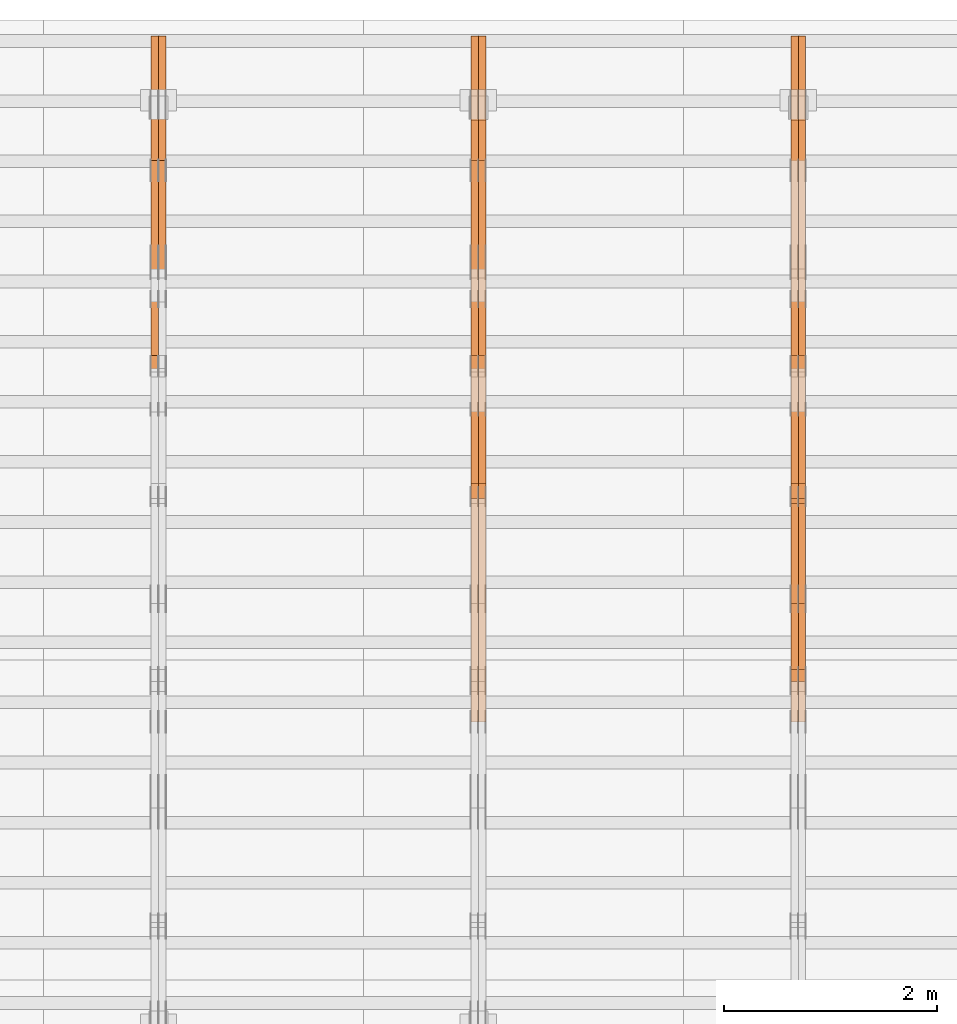
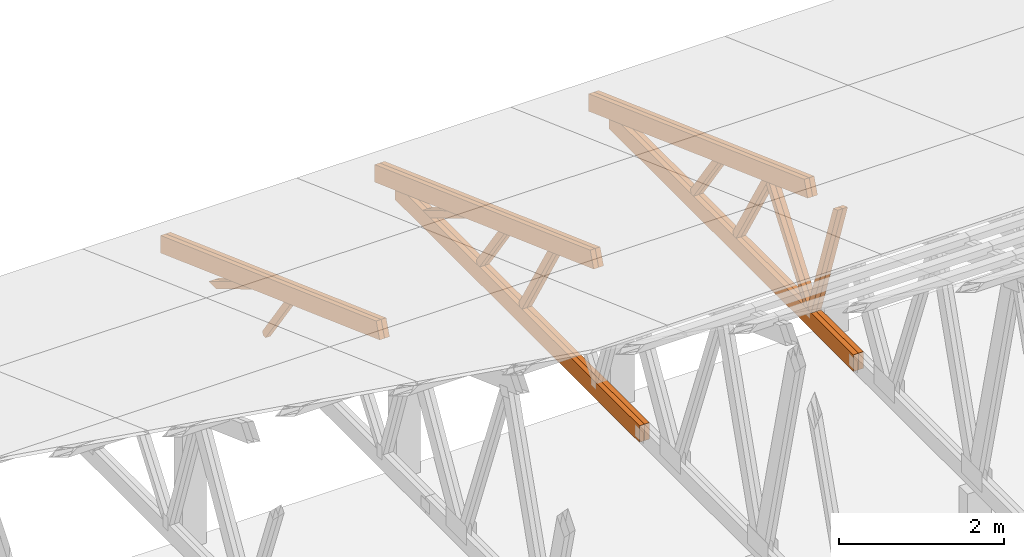
# One storey, part 43 of 189: 27 proxies.
"""IFC2X3 building model written with IfcOpenShell, lengths in millimetres."""

import ifcopenshell
import ifcopenshell.guid

model = None  # the IFC model being written
_history = None  # IfcOwnerHistory: only IFC2X3 demands one
_inside = {}  # id of a spatial element -> (the spatial element, [elements in it])
_under = {}  # id of a project, library or spatial element -> (it, [spatial elements below it])
_declared = {}  # id of a project -> (the project, [libraries it declares])
_typed = {}  # id of a type object -> (the type object, [elements of that type])
_made_of = {}  # id of a material, layer set ... -> (it, [elements and type objects made of it])


def new_model(schema):
    """Start an empty IFC model of exactly this schema.

    Asked for "IFC4X3", IfcOpenShell would pick the latest addendum, in which some entities
    have other attributes; the version numbers below select the first issue.
    IFC2X3 requires an IfcOwnerHistory on every rooted entity: one is made here for all.
    """
    global model, _history
    if schema == "IFC4X3":
        model = ifcopenshell.file(schema_version=(4, 3, 0, 0))
    else:
        model = ifcopenshell.file(schema=schema)
    _inside.clear()
    _under.clear()
    _declared.clear()
    _typed.clear()
    _made_of.clear()
    _history = None
    if model.schema == "IFC2X3":
        org = make("IfcOrganization", Name="unknown")
        user = make(
            "IfcPersonAndOrganization",
            ThePerson=make("IfcPerson", FamilyName="unknown"),
            TheOrganization=org,
        )
        app = make(
            "IfcApplication",
            ApplicationDeveloper=org,
            Version="unknown",
            ApplicationFullName="unknown",
            ApplicationIdentifier="unknown",
        )
        _history = make(
            "IfcOwnerHistory",
            OwningUser=user,
            OwningApplication=app,
            ChangeAction="ADDED",
            CreationDate=0,
        )
    return model


def make(cls, **values):
    """One entity of the class cls with the attributes given. An attribute that is None is left unset."""
    return model.create_entity(
        cls, **{name: value for name, value in values.items() if value is not None}
    )


def entity(cls, *values):
    """Any entity or typed value of the class cls, its attributes in the order of the schema. None: left unset."""
    e = model.create_entity(cls)
    for i, value in enumerate(values):
        if value is not None:
            e[i] = value
    return e


def rooted(cls, **values):
    """An entity with a GlobalId (a new one), such as an element, a storey or a relation."""
    return make(cls, GlobalId=ifcopenshell.guid.new(), OwnerHistory=_history, **values)


def si_unit(unit_type, name, prefix=None):
    """IfcSIUnit, for example si_unit("LENGTHUNIT", "METRE", prefix="MILLI")."""
    return make("IfcSIUnit", UnitType=unit_type, Prefix=prefix, Name=name)


def converted_unit(unit_type, name, factor, base, dimensions=None, offset=None):
    """IfcConversionBasedUnit, such as the inch: factor (a typed value) times the base unit."""
    return make(
        "IfcConversionBasedUnit"
        if offset is None
        else "IfcConversionBasedUnitWithOffset",
        ConversionOffset=offset,
        Dimensions=None
        if dimensions is None
        else entity("IfcDimensionalExponents", *dimensions),
        UnitType=unit_type,
        Name=name,
        ConversionFactor=make(
            "IfcMeasureWithUnit", ValueComponent=factor, UnitComponent=base
        ),
    )


def derived_unit(unit_type, elements):
    """IfcDerivedUnit: a product of units, each with its exponent."""
    return make(
        "IfcDerivedUnit",
        Elements=[
            make("IfcDerivedUnitElement", Unit=unit, Exponent=power)
            for unit, power in elements
        ],
        UnitType=unit_type,
    )


def assignment(units):
    """IfcUnitAssignment: the units of a project."""
    return None if units is None else make("IfcUnitAssignment", Units=units)


def point(xyz):
    """IfcCartesianPoint."""
    return None if xyz is None else make("IfcCartesianPoint", Coordinates=xyz)


def direction(xyz):
    """IfcDirection."""
    return None if xyz is None else make("IfcDirection", DirectionRatios=xyz)


def frame(location, z_axis=None, x_axis=None):
    """IfcAxis2Placement3D, a coordinate frame: its origin and axes. An axis left out is left unset."""
    return make(
        "IfcAxis2Placement3D",
        Location=point(location),
        Axis=direction(z_axis),
        RefDirection=direction(x_axis),
    )


def origin():
    """The frame at (0, 0, 0) with its axes left unset."""
    return frame((0.0, 0.0, 0.0))


def place(relative_to, where):
    """IfcLocalPlacement: puts the frame where relative to a parent placement (None: the world)."""
    return make(
        "IfcLocalPlacement", PlacementRelTo=relative_to, RelativePlacement=where
    )


def context(
    kind, dimensions, precision=None, world=None, true_north=None, identifier=None
):
    """IfcGeometricRepresentationContext, for example the 3D "Model" context."""
    return make(
        "IfcGeometricRepresentationContext",
        ContextIdentifier=identifier,
        ContextType=kind,
        CoordinateSpaceDimension=dimensions,
        Precision=precision,
        WorldCoordinateSystem=world,
        TrueNorth=true_north,
    )


def subcontext(parent, identifier, kind, view, scale=None):
    """IfcGeometricRepresentationSubContext, for example "Body" below "Model"."""
    return make(
        "IfcGeometricRepresentationSubContext",
        ContextIdentifier=identifier,
        ContextType=kind,
        ParentContext=parent,
        TargetScale=scale,
        TargetView=view,
    )


def project(units=None, contexts=None):
    """IfcProject with its units and contexts."""
    return rooted(
        "IfcProject",
        Name="project",
        RepresentationContexts=contexts,
        UnitsInContext=assignment(units),
    )


def spatial(cls, under=None, at=None, **own):
    """A site, building, storey or space (cls), placed at a placement, below another one or the project."""
    s = rooted(cls, ObjectPlacement=at, **own)
    if under is not None:
        _under.setdefault(under.id(), (under, []))[1].append(s)
    return s


def polyline(points):
    """IfcPolyline through the points."""
    return make("IfcPolyline", Points=[point(p) for p in points])


def outline(outer, holes=None, kind="AREA"):
    """IfcArbitraryClosedProfileDef: a profile drawn as a closed curve; with holes, ...WithVoids."""
    if holes is None:
        return make("IfcArbitraryClosedProfileDef", ProfileType=kind, OuterCurve=outer)
    return make(
        "IfcArbitraryProfileDefWithVoids",
        ProfileType=kind,
        OuterCurve=outer,
        InnerCurves=holes,
    )


def extrude(swept, where, along, depth):
    """IfcExtrudedAreaSolid: the profile swept, set in the frame where, extruded along a direction by depth."""
    return make(
        "IfcExtrudedAreaSolid",
        SweptArea=swept,
        Position=where,
        ExtrudedDirection=direction(along),
        Depth=depth,
    )


def shape(context_of_items, identifier, shape_type, items):
    """IfcShapeRepresentation: the items that make up one representation, for example the "Body"."""
    return make(
        "IfcShapeRepresentation",
        ContextOfItems=context_of_items,
        RepresentationIdentifier=identifier,
        RepresentationType=shape_type,
        Items=items,
    )


def source(mapping_origin, context_of_items, identifier, shape_type, items):
    """IfcRepresentationMap: a shape defined once, which mapped items show again and again."""
    return make(
        "IfcRepresentationMap",
        MappingOrigin=mapping_origin,
        MappedRepresentation=shape(context_of_items, identifier, shape_type, items),
    )


def transform(
    local_origin,
    x_axis=None,
    y_axis=None,
    z_axis=None,
    scale=None,
    scale2=None,
    scale3=None,
    uniform=True,
):
    """IfcCartesianTransformationOperator3D, or its non-uniform kind. x_axis, y_axis, z_axis: its Axis1, 2, 3."""
    if uniform:
        return make(
            "IfcCartesianTransformationOperator3D",
            Axis1=direction(x_axis),
            Axis2=direction(y_axis),
            LocalOrigin=point(local_origin),
            Scale=scale,
            Axis3=direction(z_axis),
        )
    return make(
        "IfcCartesianTransformationOperator3DnonUniform",
        Axis1=direction(x_axis),
        Axis2=direction(y_axis),
        LocalOrigin=point(local_origin),
        Scale=scale,
        Axis3=direction(z_axis),
        Scale2=scale2,
        Scale3=scale3,
    )


def mapped(mapping_source, mapping_target):
    """IfcMappedItem: shows the shape of a source again, moved by a transform."""
    return make(
        "IfcMappedItem", MappingSource=mapping_source, MappingTarget=mapping_target
    )


def material(Name=None, Category=None):
    """IfcMaterial."""
    return make("IfcMaterial", Name=Name, Category=Category)


def made_of(thing, what):
    """Note that an element or type object is made of a material, layer set ...; save() writes the relation."""
    if what is not None:
        _made_of.setdefault(what.id(), (what, []))[1].append(thing)
    return thing


def type_object(cls, material=None, **own):
    """A type object (cls), such as IfcWallType, which elements share."""
    return made_of(rooted(cls, **own), material)


def type_shapes(of_type, sources):
    """Give a type object the sources (RepresentationMaps) that its elements show as mapped items."""
    of_type.RepresentationMaps = sources


def element(
    cls,
    number,
    at=None,
    inside=None,
    cuts=None,
    type_object=None,
    material=None,
    context=None,
    identifier="Body",
    shape_type=None,
    held_by="IfcProductDefinitionShape",
    body=None,
    shapes=None,
    **own,
):
    """One element of the class cls, such as IfcWall. Its Tag is "e" and its number.

    at: its placement. inside: the storey or other place that contains it. cuts: it is an
    opening in that element (IfcRelVoidsElement). A single representation is given by context,
    identifier, shape_type and body (its items); several are given by shapes. held_by: the class
    of the entity that holds the representations. save() writes the other relations.
    """
    e = rooted(cls, Tag="e%d" % number, ObjectPlacement=at, **own)
    if body is not None:
        shapes = [shape(context, identifier, shape_type, body)]
    if shapes is not None:
        e.Representation = make(held_by, Representations=shapes)
    if inside is not None:
        _inside.setdefault(inside.id(), (inside, []))[1].append(e)
    if cuts is not None:
        rooted(
            "IfcRelVoidsElement", RelatingBuildingElement=cuts, RelatedOpeningElement=e
        )
    if type_object is not None:
        _typed.setdefault(type_object.id(), (type_object, []))[1].append(e)
    return made_of(e, material)


def aggregate(whole, parts):
    """IfcRelAggregates: a whole, such as a stair, and the parts it consists of."""
    return rooted("IfcRelAggregates", RelatingObject=whole, RelatedObjects=parts)


def save(model, path):
    """Write the relations noted so far, then the file.

    IfcRelAggregates (storeys below a building ...), IfcRelContainedInSpatialStructure (elements
    in a storey), IfcRelDefinesByType, IfcRelAssociatesMaterial and IfcRelDeclares: one each for
    every whole, place, type object, material and project.
    """
    for whole, parts in _under.values():
        aggregate(whole, parts)
    for where, things in _inside.values():
        rooted(
            "IfcRelContainedInSpatialStructure",
            RelatedElements=things,
            RelatingStructure=where,
        )
    for kind, things in _typed.values():
        rooted("IfcRelDefinesByType", RelatedObjects=things, RelatingType=kind)
    for what, things in _made_of.values():
        rooted("IfcRelAssociatesMaterial", RelatedObjects=things, RelatingMaterial=what)
    for by, libraries in _declared.values():
        rooted("IfcRelDeclares", RelatingContext=by, RelatedDefinitions=libraries)
    model.write(path)


model = new_model("IFC2X3")

# Units and contexts
model_context = context("Model", 3, precision=0.01, world=origin(), true_north=direction((6.12303176911189e-17, 1.0)))
body_context = subcontext(model_context, "Body", "Model", "MODEL_VIEW")
ifc_project = project(units=[si_unit("LENGTHUNIT", "METRE", prefix="MILLI"), si_unit("AREAUNIT", "SQUARE_METRE"), si_unit("VOLUMEUNIT", "CUBIC_METRE"), converted_unit("PLANEANGLEUNIT", "DEGREE", entity("IfcRatioMeasure", 0.0174532925199433), si_unit("PLANEANGLEUNIT", "RADIAN"), dimensions=[0, 0, 0, 0, 0, 0, 0]), si_unit("MASSUNIT", "GRAM", prefix="KILO"), derived_unit("MASSDENSITYUNIT", [(si_unit("MASSUNIT", "GRAM", prefix="KILO"), 1), (si_unit("LENGTHUNIT", "METRE"), -3)]), si_unit("TIMEUNIT", "SECOND"), si_unit("FREQUENCYUNIT", "HERTZ"), si_unit("THERMODYNAMICTEMPERATUREUNIT", "DEGREE_CELSIUS"), derived_unit("THERMALTRANSMITTANCEUNIT", [(si_unit("MASSUNIT", "GRAM", prefix="KILO"), 1), (si_unit("THERMODYNAMICTEMPERATUREUNIT", "KELVIN"), -1), (si_unit("TIMEUNIT", "SECOND"), -3)]), derived_unit("VOLUMETRICFLOWRATEUNIT", [(si_unit("LENGTHUNIT", "METRE"), 3), (si_unit("TIMEUNIT", "SECOND"), -1)]), si_unit("ELECTRICCURRENTUNIT", "AMPERE"), si_unit("ELECTRICVOLTAGEUNIT", "VOLT"), si_unit("POWERUNIT", "WATT"), si_unit("FORCEUNIT", "NEWTON"), si_unit("ILLUMINANCEUNIT", "LUX"), si_unit("LUMINOUSFLUXUNIT", "LUMEN"), si_unit("LUMINOUSINTENSITYUNIT", "CANDELA"), derived_unit("USERDEFINED", [(si_unit("MASSUNIT", "GRAM", prefix="KILO"), -1), (si_unit("LENGTHUNIT", "METRE"), -2), (si_unit("TIMEUNIT", "SECOND"), 3), (si_unit("LUMINOUSFLUXUNIT", "LUMEN"), 1)]), derived_unit("LINEARVELOCITYUNIT", [(si_unit("LENGTHUNIT", "METRE"), 1), (si_unit("TIMEUNIT", "SECOND"), -1)]), si_unit("PRESSUREUNIT", "PASCAL"), derived_unit("USERDEFINED", [(si_unit("LENGTHUNIT", "METRE"), -2), (si_unit("MASSUNIT", "GRAM", prefix="KILO"), 1), (si_unit("TIMEUNIT", "SECOND"), -2)])], contexts=[model_context])

# Site, building, storey
site_placement = place(None, origin())
site = spatial("IfcSite", under=ifc_project, at=site_placement, CompositionType="ELEMENT")
building_placement = place(site_placement, origin())
building = spatial("IfcBuilding", under=site, at=building_placement, CompositionType="ELEMENT")
storey_placement = place(building_placement, origin())
storey = spatial("IfcBuildingStorey", under=building, at=storey_placement, Name="Default", CompositionType="ELEMENT", Elevation=0.0)

# Proxies
ifc_material_1 = material(Name="IfcSurfaceStyle #113760")
building_element_proxy_type_1 = type_object("IfcBuildingElementProxyType", Name="T1-W9 113758", PredefinedType="NOTDEFINED", material=ifc_material_1)
shared_shape_1 = source(origin(), body_context, "Body", "SweptSolid", [
    extrude(outline(polyline([(-1151.44310138162, -47.5000079487596), (776.329826327547, -47.5000079487596), (809.267611644053, -8.1966354137375e-07), (793.242530238244, 47.5000083585914), (-1227.39686682822, 47.5000083585914), (-1151.44310138162, -47.5000079487596)])), frame((809.267685789073, 47.5000083585914, 0.0), z_axis=(0.0, 0.0, 1.0), x_axis=(-1.0, 0.0, 0.0)), (0.0, 0.0, 1.0), 69.9999999999999),
])
type_shapes(building_element_proxy_type_1, [shared_shape_1])
proxy_1_placement = place(building_placement, frame((21300.0, 24600.2198992919, 229.815691184017), z_axis=(-1.0, 0.0, 0.0), x_axis=(0.0, -0.31966811847134, 0.947529574226047)))
element("IfcBuildingElementProxy", 1, at=proxy_1_placement, inside=storey, type_object=building_element_proxy_type_1, material=ifc_material_1, Name="T1-W9", context=body_context, shape_type="MappedRepresentation", body=[
    mapped(shared_shape_1, transform((0.0, 0.0, 0.0), scale=1.0)),
])
ifc_material_2 = material(Name="IfcSurfaceStyle #113694")
building_element_proxy_type_2 = type_object("IfcBuildingElementProxyType", Name="T1-W9 113692", PredefinedType="NOTDEFINED", material=ifc_material_2)
shared_shape_2 = source(origin(), body_context, "Body", "SweptSolid", [
    extrude(outline(polyline([(-1151.44310138162, -47.5000079487596), (776.329826327547, -47.5000079487596), (809.267611644053, -8.1966354137375e-07), (793.242530238244, 47.5000083585914), (-1227.39686682822, 47.5000083585914), (-1151.44310138162, -47.5000079487596)])), frame((809.267685789073, 47.5000083585914, 0.0), z_axis=(0.0, 0.0, 1.0), x_axis=(-1.0, 0.0, 0.0)), (0.0, 0.0, 1.0), 69.9999999999999),
])
type_shapes(building_element_proxy_type_2, [shared_shape_2])
proxy_2_placement = place(building_placement, frame((21230.0, 24600.2198992919, 229.815691184017), z_axis=(-1.0, 0.0, 0.0), x_axis=(0.0, -0.31966811847134, 0.947529574226047)))
element("IfcBuildingElementProxy", 2, at=proxy_2_placement, inside=storey, type_object=building_element_proxy_type_2, material=ifc_material_2, Name="T1-W9", context=body_context, shape_type="MappedRepresentation", body=[
    mapped(shared_shape_2, transform((0.0, 0.0, 0.0), scale=1.0)),
])
ifc_material_3 = material(Name="IfcSurfaceStyle #113496")
building_element_proxy_type_3 = type_object("IfcBuildingElementProxyType", Name="T1-W10 113494", PredefinedType="NOTDEFINED", material=ifc_material_3)
shared_shape_3 = source(origin(), body_context, "Body", "SweptSolid", [
    extrude(outline(polyline([(-993.240970354386, -47.5000757607337), (635.890952815036, -47.5000757607337), (650.068145237537, -1.47580554758164e-05), (629.921374092803, 47.5000831397614), (-922.639501790989, 47.5000831397614), (-993.240970354386, -47.5000757607337)])), frame((650.068173419645, 47.5002811208496, 0.0), z_axis=(0.0, 0.0, 1.0), x_axis=(-1.0, 0.0, 0.0)), (0.0, 0.0, 1.0), 69.9999999999999),
])
type_shapes(building_element_proxy_type_3, [shared_shape_3])
proxy_3_placement = place(building_placement, frame((21300.0, 25701.688098798, 1507.2920009025), z_axis=(-1.0, 0.0, 0.0), x_axis=(0.0, -0.596486092002004, -0.802623412347395)))
element("IfcBuildingElementProxy", 3, at=proxy_3_placement, inside=storey, type_object=building_element_proxy_type_3, material=ifc_material_3, Name="T1-W10", context=body_context, shape_type="MappedRepresentation", body=[
    mapped(shared_shape_3, transform((0.0, 0.0, 0.0), scale=1.0)),
])
ifc_material_4 = material(Name="IfcSurfaceStyle #113430")
building_element_proxy_type_4 = type_object("IfcBuildingElementProxyType", Name="T1-W10 113428", PredefinedType="NOTDEFINED", material=ifc_material_4)
shared_shape_4 = source(origin(), body_context, "Body", "SweptSolid", [
    extrude(outline(polyline([(-993.240970354386, -47.5000757607337), (635.890952815036, -47.5000757607337), (650.068145237537, -1.47580554758164e-05), (629.921374092803, 47.5000831397614), (-922.639501790989, 47.5000831397614), (-993.240970354386, -47.5000757607337)])), frame((650.068173419645, 47.5002811208496, 0.0), z_axis=(0.0, 0.0, 1.0), x_axis=(-1.0, 0.0, 0.0)), (0.0, 0.0, 1.0), 69.9999999999999),
])
type_shapes(building_element_proxy_type_4, [shared_shape_4])
proxy_4_placement = place(building_placement, frame((21230.0, 25701.688098798, 1507.2920009025), z_axis=(-1.0, 0.0, 0.0), x_axis=(0.0, -0.596486092002004, -0.802623412347395)))
element("IfcBuildingElementProxy", 4, at=proxy_4_placement, inside=storey, type_object=building_element_proxy_type_4, material=ifc_material_4, Name="T1-W10", context=body_context, shape_type="MappedRepresentation", body=[
    mapped(shared_shape_4, transform((0.0, 0.0, 0.0), scale=1.0)),
])
ifc_material_5 = material(Name="IfcSurfaceStyle #113232")
building_element_proxy_type_5 = type_object("IfcBuildingElementProxyType", Name="T1-W11 113230", PredefinedType="NOTDEFINED", material=ifc_material_5)
shared_shape_5 = source(origin(), body_context, "Body", "SweptSolid", [
    extrude(outline(polyline([(-809.410890003667, -47.5000077306544), (561.624013869753, -47.5000077306544), (599.944137054867, -7.52294285037536e-05), (572.078784657538, 47.5000453453687), (-924.236045578491, 47.5000453453687), (-809.410890003667, -47.5000077306544)])), frame((599.944137054867, 47.5000453453687, 0.0), z_axis=(0.0, 0.0, 1.0), x_axis=(-1.0, 0.0, 0.0)), (0.0, 0.0, 1.0), 69.9999999999999),
])
type_shapes(building_element_proxy_type_5, [shared_shape_5])
proxy_5_placement = place(building_placement, frame((21300.0, 26434.7921369083, 220.965133687368), z_axis=(-1.0, 0.0, 0.0), x_axis=(0.0, -0.505995901100603, 0.862535882192381)))
element("IfcBuildingElementProxy", 5, at=proxy_5_placement, inside=storey, type_object=building_element_proxy_type_5, material=ifc_material_5, Name="T1-W11", context=body_context, shape_type="MappedRepresentation", body=[
    mapped(shared_shape_5, transform((0.0, 0.0, 0.0), scale=1.0)),
])
ifc_material_6 = material(Name="IfcSurfaceStyle #113166")
building_element_proxy_type_6 = type_object("IfcBuildingElementProxyType", Name="T1-W11 113164", PredefinedType="NOTDEFINED", material=ifc_material_6)
shared_shape_6 = source(origin(), body_context, "Body", "SweptSolid", [
    extrude(outline(polyline([(-809.410890003667, -47.5000077306544), (561.624013869753, -47.5000077306544), (599.944137054867, -7.52294285037536e-05), (572.078784657538, 47.5000453453687), (-924.236045578491, 47.5000453453687), (-809.410890003667, -47.5000077306544)])), frame((599.944137054867, 47.5000453453687, 0.0), z_axis=(0.0, 0.0, 1.0), x_axis=(-1.0, 0.0, 0.0)), (0.0, 0.0, 1.0), 69.9999999999999),
])
type_shapes(building_element_proxy_type_6, [shared_shape_6])
proxy_6_placement = place(building_placement, frame((21230.0, 26434.7921369083, 220.965133687368), z_axis=(-1.0, 0.0, 0.0), x_axis=(0.0, -0.505995901100603, 0.862535882192381)))
element("IfcBuildingElementProxy", 6, at=proxy_6_placement, inside=storey, type_object=building_element_proxy_type_6, material=ifc_material_6, Name="T1-W11", context=body_context, shape_type="MappedRepresentation", body=[
    mapped(shared_shape_6, transform((0.0, 0.0, 0.0), scale=1.0)),
])
ifc_material_7 = material(Name="IfcSurfaceStyle #112704")
building_element_proxy_type_7 = type_object("IfcBuildingElementProxyType", Name="T1-W13 112702", PredefinedType="NOTDEFINED", material=ifc_material_7)
shared_shape_7 = source(origin(), body_context, "Body", "SweptSolid", [
    extrude(outline(polyline([(-527.416466728212, -47.5000272833949), (387.658053197984, -47.5000272833949), (418.029495084182, -7.96824534414764e-06), (384.779443025059, 47.5000312675175), (-663.050524579013, 47.5000312675176), (-527.416466728212, -47.5000272833949)])), frame((418.029495084182, 47.5000671658844, 0.0), z_axis=(0.0, 0.0, 1.0), x_axis=(-1.0, 0.0, 0.0)), (0.0, 0.0, 1.0), 69.9999999999999),
])
type_shapes(building_element_proxy_type_7, [shared_shape_7])
proxy_7_placement = place(building_placement, frame((21300.0, 27471.0085508293, 217.760482033818), z_axis=(-1.0, 0.0, 0.0), x_axis=(0.0, -0.573462629043498, 0.819231721242848)))
element("IfcBuildingElementProxy", 7, at=proxy_7_placement, inside=storey, type_object=building_element_proxy_type_7, material=ifc_material_7, Name="T1-W13", context=body_context, shape_type="MappedRepresentation", body=[
    mapped(shared_shape_7, transform((0.0, 0.0, 0.0), scale=1.0)),
])
ifc_material_8 = material(Name="IfcSurfaceStyle #112638")
building_element_proxy_type_8 = type_object("IfcBuildingElementProxyType", Name="T1-W13 112636", PredefinedType="NOTDEFINED", material=ifc_material_8)
shared_shape_8 = source(origin(), body_context, "Body", "SweptSolid", [
    extrude(outline(polyline([(-527.416466728212, -47.5000272833949), (387.658053197984, -47.5000272833949), (418.029495084182, -7.96824534414764e-06), (384.779443025059, 47.5000312675175), (-663.050524579013, 47.5000312675176), (-527.416466728212, -47.5000272833949)])), frame((418.029495084182, 47.5000671658844, 0.0), z_axis=(0.0, 0.0, 1.0), x_axis=(-1.0, 0.0, 0.0)), (0.0, 0.0, 1.0), 69.9999999999999),
])
type_shapes(building_element_proxy_type_8, [shared_shape_8])
proxy_8_placement = place(building_placement, frame((21230.0, 27471.0085508293, 217.760482033818), z_axis=(-1.0, 0.0, 0.0), x_axis=(0.0, -0.573462629043498, 0.819231721242848)))
element("IfcBuildingElementProxy", 8, at=proxy_8_placement, inside=storey, type_object=building_element_proxy_type_8, material=ifc_material_8, Name="T1-W13", context=body_context, shape_type="MappedRepresentation", body=[
    mapped(shared_shape_8, transform((0.0, 0.0, 0.0), scale=1.0)),
])
ifc_material_9 = material(Name="IfcSurfaceStyle #112080")
building_element_proxy_type_9 = type_object("IfcBuildingElementProxyType", Name="T1-B1 112078", PredefinedType="NOTDEFINED", material=ifc_material_9)
shared_shape_9 = source(origin(), body_context, "Body", "SweptSolid", [
    extrude(outline(polyline([(-2430.09461669922, -125.855288696288), (3499.90538330078, -125.855288696288), (3499.90538330078, 119.144711303711), (-2139.62153320312, 119.144711303711), (-2430.09461669922, 13.4211547851552), (-2430.09461669922, -125.855288696288)])), frame((3499.90538330078, 119.144711303711, 0.0), z_axis=(0.0, 0.0, 1.0), x_axis=(-1.0, 0.0, 0.0)), (0.0, 0.0, 1.0), 69.9999999999996),
])
type_shapes(building_element_proxy_type_9, [shared_shape_9])
proxy_9_placement = place(building_placement, frame((21300.0, 23570.0, 245.0), z_axis=(-1.0, 0.0, 0.0), x_axis=(0.0, 1.0, 0.0)))
element("IfcBuildingElementProxy", 9, at=proxy_9_placement, inside=storey, type_object=building_element_proxy_type_9, material=ifc_material_9, Name="T1-B1", context=body_context, shape_type="MappedRepresentation", body=[
    mapped(shared_shape_9, transform((0.0, 0.0, 0.0), scale=1.0)),
])
ifc_material_10 = material(Name="IfcSurfaceStyle #112014")
building_element_proxy_type_10 = type_object("IfcBuildingElementProxyType", Name="T1-B1 112012", PredefinedType="NOTDEFINED", material=ifc_material_10)
shared_shape_10 = source(origin(), body_context, "Body", "SweptSolid", [
    extrude(outline(polyline([(-2430.09461669922, -125.855288696288), (3499.90538330078, -125.855288696288), (3499.90538330078, 119.144711303711), (-2139.62153320312, 119.144711303711), (-2430.09461669922, 13.4211547851552), (-2430.09461669922, -125.855288696288)])), frame((3499.90538330078, 119.144711303711, 0.0), z_axis=(0.0, 0.0, 1.0), x_axis=(-1.0, 0.0, 0.0)), (0.0, 0.0, 1.0), 69.9999999999996),
])
type_shapes(building_element_proxy_type_10, [shared_shape_10])
proxy_10_placement = place(building_placement, frame((21230.0, 23570.0, 245.0), z_axis=(-1.0, 0.0, 0.0), x_axis=(0.0, 1.0, 0.0)))
element("IfcBuildingElementProxy", 10, at=proxy_10_placement, inside=storey, type_object=building_element_proxy_type_10, material=ifc_material_10, Name="T1-B1", context=body_context, shape_type="MappedRepresentation", body=[
    mapped(shared_shape_10, transform((0.0, 0.0, 0.0), scale=1.0)),
])
ifc_material_11 = material(Name="IfcSurfaceStyle #110790")
building_element_proxy_type_11 = type_object("IfcBuildingElementProxyType", Name="T1-T2 110788", PredefinedType="NOTDEFINED", material=ifc_material_11)
shared_shape_11 = source(origin(), body_context, "Body", "SweptSolid", [
    extrude(outline(polyline([(-2807.70681121203, -122.500041939424), (2763.12044548192, -122.500041939424), (2852.29315104137, 122.500041939424), (-2807.70678531126, 122.500041939424), (-2807.70681121203, -122.500041939424)])), frame((2852.29315104137, 122.500041939424, 0.0), z_axis=(0.0, 0.0, 1.0), x_axis=(-1.0, 0.0, 0.0)), (0.0, 0.0, 1.0), 69.9999999999997),
])
type_shapes(building_element_proxy_type_11, [shared_shape_11])
proxy_11_placement = place(building_placement, frame((21300.0, 30000.0, -42.7086715698242), z_axis=(-1.0, 0.0, 0.0), x_axis=(0.0, -0.939692620785908, 0.342020143325669)))
element("IfcBuildingElementProxy", 11, at=proxy_11_placement, inside=storey, type_object=building_element_proxy_type_11, material=ifc_material_11, Name="T1-T2", context=body_context, shape_type="MappedRepresentation", body=[
    mapped(shared_shape_11, transform((0.0, 0.0, 0.0), scale=1.0)),
])
ifc_material_12 = material(Name="IfcSurfaceStyle #110733")
building_element_proxy_type_12 = type_object("IfcBuildingElementProxyType", Name="T1-T2 110731", PredefinedType="NOTDEFINED", material=ifc_material_12)
shared_shape_12 = source(origin(), body_context, "Body", "SweptSolid", [
    extrude(outline(polyline([(-2807.70681121203, -122.500041939424), (2763.12044548192, -122.500041939424), (2852.29315104137, 122.500041939424), (-2807.70678531126, 122.500041939424), (-2807.70681121203, -122.500041939424)])), frame((2852.29315104137, 122.500041939424, 0.0), z_axis=(0.0, 0.0, 1.0), x_axis=(-1.0, 0.0, 0.0)), (0.0, 0.0, 1.0), 69.9999999999997),
])
type_shapes(building_element_proxy_type_12, [shared_shape_12])
proxy_12_placement = place(building_placement, frame((21230.0, 30000.0, -42.7086715698242), z_axis=(-1.0, 0.0, 0.0), x_axis=(0.0, -0.939692620785908, 0.342020143325669)))
element("IfcBuildingElementProxy", 12, at=proxy_12_placement, inside=storey, type_object=building_element_proxy_type_12, material=ifc_material_12, Name="T1-T2", context=body_context, shape_type="MappedRepresentation", body=[
    mapped(shared_shape_12, transform((0.0, 0.0, 0.0), scale=1.0)),
])
ifc_material_13 = material(Name="IfcSurfaceStyle #97442")
building_element_proxy_type_13 = type_object("IfcBuildingElementProxyType", Name="T1-W11 97440", PredefinedType="NOTDEFINED", material=ifc_material_13)
shared_shape_13 = source(origin(), body_context, "Body", "SweptSolid", [
    extrude(outline(polyline([(-809.410890003667, -47.5000077306544), (561.624013869753, -47.5000077306544), (599.944137054867, -7.52294285037536e-05), (572.078784657538, 47.5000453453687), (-924.236045578491, 47.5000453453687), (-809.410890003667, -47.5000077306544)])), frame((599.944137054867, 47.5000453453687, 0.0), z_axis=(0.0, 0.0, 1.0), x_axis=(-1.0, 0.0, 0.0)), (0.0, 0.0, 1.0), 69.9999999999999),
])
type_shapes(building_element_proxy_type_13, [shared_shape_13])
proxy_13_placement = place(building_placement, frame((18300.0, 26434.7921369083, 220.965133687368), z_axis=(-1.0, 0.0, 0.0), x_axis=(0.0, -0.505995901100603, 0.862535882192381)))
element("IfcBuildingElementProxy", 13, at=proxy_13_placement, inside=storey, type_object=building_element_proxy_type_13, material=ifc_material_13, Name="T1-W11", context=body_context, shape_type="MappedRepresentation", body=[
    mapped(shared_shape_13, transform((0.0, 0.0, 0.0), scale=1.0)),
])
ifc_material_14 = material(Name="IfcSurfaceStyle #97376")
building_element_proxy_type_14 = type_object("IfcBuildingElementProxyType", Name="T1-W11 97374", PredefinedType="NOTDEFINED", material=ifc_material_14)
shared_shape_14 = source(origin(), body_context, "Body", "SweptSolid", [
    extrude(outline(polyline([(-809.410890003667, -47.5000077306544), (561.624013869753, -47.5000077306544), (599.944137054867, -7.52294285037536e-05), (572.078784657538, 47.5000453453687), (-924.236045578491, 47.5000453453687), (-809.410890003667, -47.5000077306544)])), frame((599.944137054867, 47.5000453453687, 0.0), z_axis=(0.0, 0.0, 1.0), x_axis=(-1.0, 0.0, 0.0)), (0.0, 0.0, 1.0), 69.9999999999999),
])
type_shapes(building_element_proxy_type_14, [shared_shape_14])
proxy_14_placement = place(building_placement, frame((18230.0, 26434.7921369083, 220.965133687368), z_axis=(-1.0, 0.0, 0.0), x_axis=(0.0, -0.505995901100603, 0.862535882192381)))
element("IfcBuildingElementProxy", 14, at=proxy_14_placement, inside=storey, type_object=building_element_proxy_type_14, material=ifc_material_14, Name="T1-W11", context=body_context, shape_type="MappedRepresentation", body=[
    mapped(shared_shape_14, transform((0.0, 0.0, 0.0), scale=1.0)),
])
ifc_material_15 = material(Name="IfcSurfaceStyle #96914")
building_element_proxy_type_15 = type_object("IfcBuildingElementProxyType", Name="T1-W13 96912", PredefinedType="NOTDEFINED", material=ifc_material_15)
shared_shape_15 = source(origin(), body_context, "Body", "SweptSolid", [
    extrude(outline(polyline([(-527.416466728212, -47.5000272833949), (387.658053197984, -47.5000272833949), (418.029495084182, -7.96824534414764e-06), (384.779443025059, 47.5000312675175), (-663.050524579013, 47.5000312675176), (-527.416466728212, -47.5000272833949)])), frame((418.029495084182, 47.5000671658844, 0.0), z_axis=(0.0, 0.0, 1.0), x_axis=(-1.0, 0.0, 0.0)), (0.0, 0.0, 1.0), 69.9999999999999),
])
type_shapes(building_element_proxy_type_15, [shared_shape_15])
proxy_15_placement = place(building_placement, frame((18300.0, 27471.0085508293, 217.760482033818), z_axis=(-1.0, 0.0, 0.0), x_axis=(0.0, -0.573462629043498, 0.819231721242848)))
element("IfcBuildingElementProxy", 15, at=proxy_15_placement, inside=storey, type_object=building_element_proxy_type_15, material=ifc_material_15, Name="T1-W13", context=body_context, shape_type="MappedRepresentation", body=[
    mapped(shared_shape_15, transform((0.0, 0.0, 0.0), scale=1.0)),
])
ifc_material_16 = material(Name="IfcSurfaceStyle #96848")
building_element_proxy_type_16 = type_object("IfcBuildingElementProxyType", Name="T1-W13 96846", PredefinedType="NOTDEFINED", material=ifc_material_16)
shared_shape_16 = source(origin(), body_context, "Body", "SweptSolid", [
    extrude(outline(polyline([(-527.416466728212, -47.5000272833949), (387.658053197984, -47.5000272833949), (418.029495084182, -7.96824534414764e-06), (384.779443025059, 47.5000312675175), (-663.050524579013, 47.5000312675176), (-527.416466728212, -47.5000272833949)])), frame((418.029495084182, 47.5000671658844, 0.0), z_axis=(0.0, 0.0, 1.0), x_axis=(-1.0, 0.0, 0.0)), (0.0, 0.0, 1.0), 69.9999999999999),
])
type_shapes(building_element_proxy_type_16, [shared_shape_16])
proxy_16_placement = place(building_placement, frame((18230.0, 27471.0085508293, 217.760482033818), z_axis=(-1.0, 0.0, 0.0), x_axis=(0.0, -0.573462629043498, 0.819231721242848)))
element("IfcBuildingElementProxy", 16, at=proxy_16_placement, inside=storey, type_object=building_element_proxy_type_16, material=ifc_material_16, Name="T1-W13", context=body_context, shape_type="MappedRepresentation", body=[
    mapped(shared_shape_16, transform((0.0, 0.0, 0.0), scale=1.0)),
])
ifc_material_17 = material(Name="IfcSurfaceStyle #96404")
building_element_proxy_type_17 = type_object("IfcBuildingElementProxyType", Name="T1-W12 96402", PredefinedType="NOTDEFINED", material=ifc_material_17)
shared_shape_17 = source(origin(), body_context, "Body", "SweptSolid", [
    extrude(outline(polyline([(-176.861423449428, -47.5000064161489), (503.856777435794, -47.5000064161489), (344.893496040196, 47.5000064161489), (-671.888850026563, 47.5000064161488), (-176.861423449428, -47.5000064161489)])), frame((503.856799890979, 47.5000428456028, 0.0), z_axis=(0.0, 0.0, 1.0), x_axis=(-1.0, 0.0, 0.0)), (0.0, 0.0, 1.0), 69.9999999999999),
])
type_shapes(building_element_proxy_type_17, [shared_shape_17])
proxy_17_placement = place(building_placement, frame((18300.0, 28785.6842742264, 163.452728724015), z_axis=(-1.0, 0.0, 0.0), x_axis=(0.0, -0.858392121304013, 0.51299411895576)))
element("IfcBuildingElementProxy", 17, at=proxy_17_placement, inside=storey, type_object=building_element_proxy_type_17, material=ifc_material_17, Name="T1-W12", context=body_context, shape_type="MappedRepresentation", body=[
    mapped(shared_shape_17, transform((0.0, 0.0, 0.0), scale=1.0)),
])
ifc_material_18 = material(Name="IfcSurfaceStyle #96347")
building_element_proxy_type_18 = type_object("IfcBuildingElementProxyType", Name="T1-W12 96345", PredefinedType="NOTDEFINED", material=ifc_material_18)
shared_shape_18 = source(origin(), body_context, "Body", "SweptSolid", [
    extrude(outline(polyline([(-176.861423449428, -47.5000064161489), (503.856777435794, -47.5000064161489), (344.893496040196, 47.5000064161489), (-671.888850026563, 47.5000064161488), (-176.861423449428, -47.5000064161489)])), frame((503.856799890979, 47.5000428456028, 0.0), z_axis=(0.0, 0.0, 1.0), x_axis=(-1.0, 0.0, 0.0)), (0.0, 0.0, 1.0), 69.9999999999999),
])
type_shapes(building_element_proxy_type_18, [shared_shape_18])
proxy_18_placement = place(building_placement, frame((18230.0, 28785.6842742264, 163.452728724015), z_axis=(-1.0, 0.0, 0.0), x_axis=(0.0, -0.858392121304013, 0.51299411895576)))
element("IfcBuildingElementProxy", 18, at=proxy_18_placement, inside=storey, type_object=building_element_proxy_type_18, material=ifc_material_18, Name="T1-W12", context=body_context, shape_type="MappedRepresentation", body=[
    mapped(shared_shape_18, transform((0.0, 0.0, 0.0), scale=1.0)),
])
ifc_material_19 = material(Name="IfcSurfaceStyle #96290")
building_element_proxy_type_19 = type_object("IfcBuildingElementProxyType", Name="T1-B1 96288", PredefinedType="NOTDEFINED", material=ifc_material_19)
shared_shape_19 = source(origin(), body_context, "Body", "SweptSolid", [
    extrude(outline(polyline([(-2430.09461669922, -125.855288696288), (3499.90538330078, -125.855288696288), (3499.90538330078, 119.144711303711), (-2139.62153320312, 119.144711303711), (-2430.09461669922, 13.4211547851552), (-2430.09461669922, -125.855288696288)])), frame((3499.90538330078, 119.144711303711, 0.0), z_axis=(0.0, 0.0, 1.0), x_axis=(-1.0, 0.0, 0.0)), (0.0, 0.0, 1.0), 69.9999999999996),
])
type_shapes(building_element_proxy_type_19, [shared_shape_19])
proxy_19_placement = place(building_placement, frame((18300.0, 23570.0, 245.0), z_axis=(-1.0, 0.0, 0.0), x_axis=(0.0, 1.0, 0.0)))
element("IfcBuildingElementProxy", 19, at=proxy_19_placement, inside=storey, type_object=building_element_proxy_type_19, material=ifc_material_19, Name="T1-B1", context=body_context, shape_type="MappedRepresentation", body=[
    mapped(shared_shape_19, transform((0.0, 0.0, 0.0), scale=1.0)),
])
ifc_material_20 = material(Name="IfcSurfaceStyle #96224")
building_element_proxy_type_20 = type_object("IfcBuildingElementProxyType", Name="T1-B1 96222", PredefinedType="NOTDEFINED", material=ifc_material_20)
shared_shape_20 = source(origin(), body_context, "Body", "SweptSolid", [
    extrude(outline(polyline([(-2430.09461669922, -125.855288696288), (3499.90538330078, -125.855288696288), (3499.90538330078, 119.144711303711), (-2139.62153320312, 119.144711303711), (-2430.09461669922, 13.4211547851552), (-2430.09461669922, -125.855288696288)])), frame((3499.90538330078, 119.144711303711, 0.0), z_axis=(0.0, 0.0, 1.0), x_axis=(-1.0, 0.0, 0.0)), (0.0, 0.0, 1.0), 69.9999999999996),
])
type_shapes(building_element_proxy_type_20, [shared_shape_20])
proxy_20_placement = place(building_placement, frame((18230.0, 23570.0, 245.0), z_axis=(-1.0, 0.0, 0.0), x_axis=(0.0, 1.0, 0.0)))
element("IfcBuildingElementProxy", 20, at=proxy_20_placement, inside=storey, type_object=building_element_proxy_type_20, material=ifc_material_20, Name="T1-B1", context=body_context, shape_type="MappedRepresentation", body=[
    mapped(shared_shape_20, transform((0.0, 0.0, 0.0), scale=1.0)),
])
ifc_material_21 = material(Name="IfcSurfaceStyle #95000")
building_element_proxy_type_21 = type_object("IfcBuildingElementProxyType", Name="T1-T2 94998", PredefinedType="NOTDEFINED", material=ifc_material_21)
shared_shape_21 = source(origin(), body_context, "Body", "SweptSolid", [
    extrude(outline(polyline([(-2807.70681121203, -122.500041939424), (2763.12044548192, -122.500041939424), (2852.29315104137, 122.500041939424), (-2807.70678531126, 122.500041939424), (-2807.70681121203, -122.500041939424)])), frame((2852.29315104137, 122.500041939424, 0.0), z_axis=(0.0, 0.0, 1.0), x_axis=(-1.0, 0.0, 0.0)), (0.0, 0.0, 1.0), 69.9999999999997),
])
type_shapes(building_element_proxy_type_21, [shared_shape_21])
proxy_21_placement = place(building_placement, frame((18300.0, 30000.0, -42.7086715698242), z_axis=(-1.0, 0.0, 0.0), x_axis=(0.0, -0.939692620785908, 0.342020143325669)))
element("IfcBuildingElementProxy", 21, at=proxy_21_placement, inside=storey, type_object=building_element_proxy_type_21, material=ifc_material_21, Name="T1-T2", context=body_context, shape_type="MappedRepresentation", body=[
    mapped(shared_shape_21, transform((0.0, 0.0, 0.0), scale=1.0)),
])
ifc_material_22 = material(Name="IfcSurfaceStyle #94943")
building_element_proxy_type_22 = type_object("IfcBuildingElementProxyType", Name="T1-T2 94941", PredefinedType="NOTDEFINED", material=ifc_material_22)
shared_shape_22 = source(origin(), body_context, "Body", "SweptSolid", [
    extrude(outline(polyline([(-2807.70681121203, -122.500041939424), (2763.12044548192, -122.500041939424), (2852.29315104137, 122.500041939424), (-2807.70678531126, 122.500041939424), (-2807.70681121203, -122.500041939424)])), frame((2852.29315104137, 122.500041939424, 0.0), z_axis=(0.0, 0.0, 1.0), x_axis=(-1.0, 0.0, 0.0)), (0.0, 0.0, 1.0), 69.9999999999997),
])
type_shapes(building_element_proxy_type_22, [shared_shape_22])
proxy_22_placement = place(building_placement, frame((18230.0, 30000.0, -42.7086715698242), z_axis=(-1.0, 0.0, 0.0), x_axis=(0.0, -0.939692620785908, 0.342020143325669)))
element("IfcBuildingElementProxy", 22, at=proxy_22_placement, inside=storey, type_object=building_element_proxy_type_22, material=ifc_material_22, Name="T1-T2", context=body_context, shape_type="MappedRepresentation", body=[
    mapped(shared_shape_22, transform((0.0, 0.0, 0.0), scale=1.0)),
])
ifc_material_23 = material(Name="IfcSurfaceStyle #81058")
building_element_proxy_type_23 = type_object("IfcBuildingElementProxyType", Name="T1-W13 81056", PredefinedType="NOTDEFINED", material=ifc_material_23)
shared_shape_23 = source(origin(), body_context, "Body", "SweptSolid", [
    extrude(outline(polyline([(-527.416466728212, -47.5000272833949), (387.658053197984, -47.5000272833949), (418.029495084182, -7.96824534414764e-06), (384.779443025059, 47.5000312675175), (-663.050524579013, 47.5000312675176), (-527.416466728212, -47.5000272833949)])), frame((418.029495084182, 47.5000671658844, 0.0), z_axis=(0.0, 0.0, 1.0), x_axis=(-1.0, 0.0, 0.0)), (0.0, 0.0, 1.0), 69.9999999999999),
])
type_shapes(building_element_proxy_type_23, [shared_shape_23])
proxy_23_placement = place(building_placement, frame((15230.0, 27471.0085508293, 217.760482033818), z_axis=(-1.0, 0.0, 0.0), x_axis=(0.0, -0.573462629043498, 0.819231721242848)))
element("IfcBuildingElementProxy", 23, at=proxy_23_placement, inside=storey, type_object=building_element_proxy_type_23, material=ifc_material_23, Name="T1-W13", context=body_context, shape_type="MappedRepresentation", body=[
    mapped(shared_shape_23, transform((0.0, 0.0, 0.0), scale=1.0)),
])
ifc_material_24 = material(Name="IfcSurfaceStyle #80614")
building_element_proxy_type_24 = type_object("IfcBuildingElementProxyType", Name="T1-W12 80612", PredefinedType="NOTDEFINED", material=ifc_material_24)
shared_shape_24 = source(origin(), body_context, "Body", "SweptSolid", [
    extrude(outline(polyline([(-176.861423449428, -47.5000064161489), (503.856777435794, -47.5000064161489), (344.893496040196, 47.5000064161489), (-671.888850026563, 47.5000064161488), (-176.861423449428, -47.5000064161489)])), frame((503.856799890979, 47.5000428456028, 0.0), z_axis=(0.0, 0.0, 1.0), x_axis=(-1.0, 0.0, 0.0)), (0.0, 0.0, 1.0), 69.9999999999999),
])
type_shapes(building_element_proxy_type_24, [shared_shape_24])
proxy_24_placement = place(building_placement, frame((15300.0, 28785.6842742264, 163.452728724015), z_axis=(-1.0, 0.0, 0.0), x_axis=(0.0, -0.858392121304013, 0.51299411895576)))
element("IfcBuildingElementProxy", 24, at=proxy_24_placement, inside=storey, type_object=building_element_proxy_type_24, material=ifc_material_24, Name="T1-W12", context=body_context, shape_type="MappedRepresentation", body=[
    mapped(shared_shape_24, transform((0.0, 0.0, 0.0), scale=1.0)),
])
ifc_material_25 = material(Name="IfcSurfaceStyle #80557")
building_element_proxy_type_25 = type_object("IfcBuildingElementProxyType", Name="T1-W12 80555", PredefinedType="NOTDEFINED", material=ifc_material_25)
shared_shape_25 = source(origin(), body_context, "Body", "SweptSolid", [
    extrude(outline(polyline([(-176.861423449428, -47.5000064161489), (503.856777435794, -47.5000064161489), (344.893496040196, 47.5000064161489), (-671.888850026563, 47.5000064161488), (-176.861423449428, -47.5000064161489)])), frame((503.856799890979, 47.5000428456028, 0.0), z_axis=(0.0, 0.0, 1.0), x_axis=(-1.0, 0.0, 0.0)), (0.0, 0.0, 1.0), 69.9999999999999),
])
type_shapes(building_element_proxy_type_25, [shared_shape_25])
proxy_25_placement = place(building_placement, frame((15230.0, 28785.6842742264, 163.452728724015), z_axis=(-1.0, 0.0, 0.0), x_axis=(0.0, -0.858392121304013, 0.51299411895576)))
element("IfcBuildingElementProxy", 25, at=proxy_25_placement, inside=storey, type_object=building_element_proxy_type_25, material=ifc_material_25, Name="T1-W12", context=body_context, shape_type="MappedRepresentation", body=[
    mapped(shared_shape_25, transform((0.0, 0.0, 0.0), scale=1.0)),
])
ifc_material_26 = material(Name="IfcSurfaceStyle #79210")
building_element_proxy_type_26 = type_object("IfcBuildingElementProxyType", Name="T1-T2 79208", PredefinedType="NOTDEFINED", material=ifc_material_26)
shared_shape_26 = source(origin(), body_context, "Body", "SweptSolid", [
    extrude(outline(polyline([(-2807.70681121203, -122.500041939424), (2763.12044548192, -122.500041939424), (2852.29315104137, 122.500041939424), (-2807.70678531126, 122.500041939424), (-2807.70681121203, -122.500041939424)])), frame((2852.29315104137, 122.500041939424, 0.0), z_axis=(0.0, 0.0, 1.0), x_axis=(-1.0, 0.0, 0.0)), (0.0, 0.0, 1.0), 69.9999999999997),
])
type_shapes(building_element_proxy_type_26, [shared_shape_26])
proxy_26_placement = place(building_placement, frame((15300.0, 30000.0, -42.7086715698242), z_axis=(-1.0, 0.0, 0.0), x_axis=(0.0, -0.939692620785908, 0.342020143325669)))
element("IfcBuildingElementProxy", 26, at=proxy_26_placement, inside=storey, type_object=building_element_proxy_type_26, material=ifc_material_26, Name="T1-T2", context=body_context, shape_type="MappedRepresentation", body=[
    mapped(shared_shape_26, transform((0.0, 0.0, 0.0), scale=1.0)),
])
ifc_material_27 = material(Name="IfcSurfaceStyle #79153")
building_element_proxy_type_27 = type_object("IfcBuildingElementProxyType", Name="T1-T2 79151", PredefinedType="NOTDEFINED", material=ifc_material_27)
shared_shape_27 = source(origin(), body_context, "Body", "SweptSolid", [
    extrude(outline(polyline([(-2807.70681121203, -122.500041939424), (2763.12044548192, -122.500041939424), (2852.29315104137, 122.500041939424), (-2807.70678531126, 122.500041939424), (-2807.70681121203, -122.500041939424)])), frame((2852.29315104137, 122.500041939424, 0.0), z_axis=(0.0, 0.0, 1.0), x_axis=(-1.0, 0.0, 0.0)), (0.0, 0.0, 1.0), 69.9999999999997),
])
type_shapes(building_element_proxy_type_27, [shared_shape_27])
proxy_27_placement = place(building_placement, frame((15230.0, 30000.0, -42.7086715698242), z_axis=(-1.0, 0.0, 0.0), x_axis=(0.0, -0.939692620785908, 0.342020143325669)))
element("IfcBuildingElementProxy", 27, at=proxy_27_placement, inside=storey, type_object=building_element_proxy_type_27, material=ifc_material_27, Name="T1-T2", context=body_context, shape_type="MappedRepresentation", body=[
    mapped(shared_shape_27, transform((0.0, 0.0, 0.0), scale=1.0)),
])

save(model, "model.ifc")
